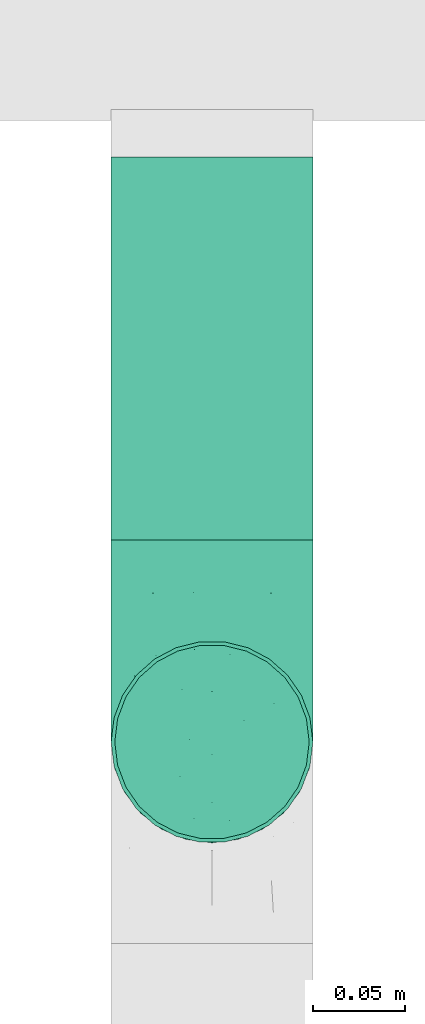
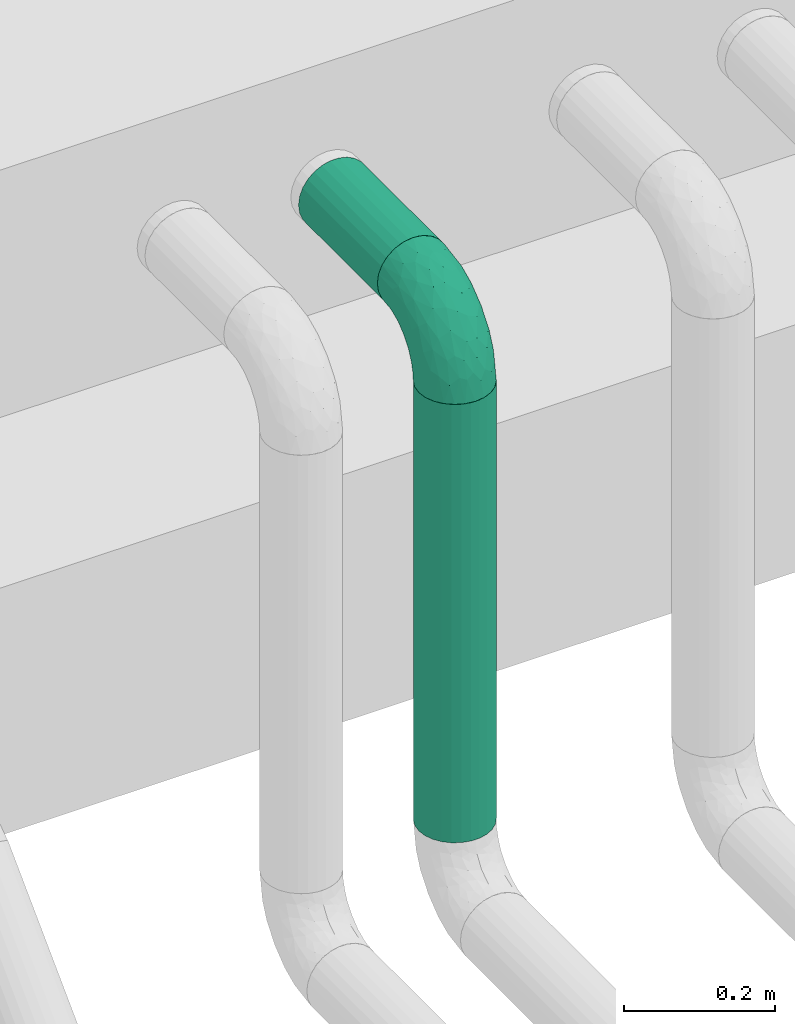
# One storey, part 8 of 91: 2 flow segments, 1 flow fitting.
"""IFC2X3 building model written with IfcOpenShell, lengths in millimetres."""

from ifc_helpers import new_model, entity, si_unit, converted_unit, derived_unit, direction, frame, origin_with_axes, origin_2d_with_axis, place, context, subcontext, project, spatial, hollow_circle, extrude, open_shell, surface_model, source, transform, mapped, material, layer, layer_set, layer_usage, type_object, element, save


model = new_model("IFC2X3")

# Units and contexts
model_context = context("Model", 3, precision=1e-05, world=origin_with_axes(), true_north=direction((0.0, 1.0)))
body_context = subcontext(model_context, "Body", "Model", "MODEL_VIEW")
ifc_project = project(units=[si_unit("AREAUNIT", "SQUARE_METRE"), si_unit("VOLUMEUNIT", "CUBIC_METRE", prefix="DECI"), si_unit("TIMEUNIT", "SECOND"), si_unit("THERMODYNAMICTEMPERATUREUNIT", "DEGREE_CELSIUS"), si_unit("PRESSUREUNIT", "PASCAL"), si_unit("MASSUNIT", "GRAM", prefix="KILO"), si_unit("LENGTHUNIT", "METRE", prefix="MILLI"), si_unit("POWERUNIT", "WATT"), si_unit("ELECTRICCURRENTUNIT", "AMPERE"), si_unit("ELECTRICVOLTAGEUNIT", "VOLT"), derived_unit("VOLUMETRICFLOWRATEUNIT", [(si_unit("VOLUMEUNIT", "CUBIC_METRE", prefix="DECI"), 1), (si_unit("TIMEUNIT", "SECOND"), -1)]), derived_unit("LINEARVELOCITYUNIT", [(si_unit("LENGTHUNIT", "METRE"), 1), (si_unit("TIMEUNIT", "SECOND"), -1)]), derived_unit("MASSDENSITYUNIT", [(si_unit("MASSUNIT", "GRAM", prefix="KILO"), 1), (si_unit("VOLUMEUNIT", "CUBIC_METRE"), -1)]), converted_unit("PLANEANGLEUNIT", "DEGREE", entity("IfcRatioMeasure", 0.01745), si_unit("PLANEANGLEUNIT", "RADIAN"), dimensions=[0, 0, 0, 0, 0, 0, 0])], contexts=[model_context])

# Site, building, storey
site_placement = place(None, origin_with_axes())
site = spatial("IfcSite", under=ifc_project, at=site_placement, CompositionType="ELEMENT")
building_placement = place(site_placement, origin_with_axes())
building = spatial("IfcBuilding", under=site, at=building_placement, Name="mc-building", CompositionType="ELEMENT")
storey_placement = place(building_placement, frame((0.0, 0.0, 8700.0), z_axis=(0.0, 0.0, 1.0), x_axis=(1.0, 0.0, 0.0)))
storey = spatial("IfcBuildingStorey", under=building, at=storey_placement, CompositionType="ELEMENT", Elevation=8700.0)

# Flow segments
ifc_material = material(Name="FZ1")
ifc_layer = layer(ifc_material, 0.0)
ifc_layer_set = layer_set([ifc_layer], Name="FZ1")
ifc_layer_usage = layer_usage(ifc_layer_set, "AXIS1", "POSITIVE", 0.0)
duct_segment_type = type_object("IfcDuctSegmentType", PredefinedType="RIGIDSEGMENT")
shared_shape_1 = source(origin_with_axes(), body_context, "Body", "SweptSolid", [
    extrude(hollow_circle(Radius=55.0, WallThickness=2.0, at=origin_2d_with_axis()), frame((0.0, 0.0, 0.0), z_axis=(1.0, 0.0, 0.0), x_axis=(0.0, 1.0, 0.0)), (0.0, 0.0, 1.0), 709.0),
])
flow_segment_1_placement = place(storey_placement, frame((8592.78509, 2612.35324, 1234.0), z_axis=(0.0, 1.0, 0.0), x_axis=(0.0, 0.0, -1.0)))
element("IfcFlowSegment", 1, at=flow_segment_1_placement, inside=storey, type_object=duct_segment_type, material=ifc_layer_usage, context=body_context, shape_type="MappedRepresentation", body=[
    mapped(shared_shape_1, transform((0.0, 0.0, 0.0), scale=1.0)),
])
shared_shape_2 = source(origin_with_axes(), body_context, "Body", "SweptSolid", [
    extrude(hollow_circle(Radius=55.0, WallThickness=2.0, at=origin_2d_with_axis()), frame((0.0, 0.0, 0.0), z_axis=(1.0, 0.0, 0.0), x_axis=(0.0, 1.0, 0.0)), (0.0, 0.0, 1.0), 208.9),
])
flow_segment_2_placement = place(storey_placement, frame((8592.78509, 2931.20513, 1344.0), z_axis=(0.0, 0.0, 1.0), x_axis=(0.0, -1.0, 0.0)))
element("IfcFlowSegment", 2, at=flow_segment_2_placement, inside=storey, type_object=duct_segment_type, material=ifc_layer_usage, context=body_context, shape_type="MappedRepresentation", body=[
    mapped(shared_shape_2, transform((0.0, 0.0, 0.0), scale=1.0, scale2=1.0, scale3=1.0, uniform=False)),
])

# Flow fitting
duct_fitting_type = type_object("IfcDuctFittingType", Name="BU", PredefinedType="BEND")
shared_shape_3 = source(origin_with_axes(), body_context, "Body", "SurfaceModel", [
    surface_model("IfcShellBasedSurfaceModel", [(-110.0, 0.0, -55.0), (-110.0, -14.23505, -53.12592), (-110.0, 14.23505, -53.12592), (-110.0, 53.12592, 14.23505), (-110.0, 27.5, -47.63139), (-110.0, 38.89087, -38.89087), (-110.0, -55.0, 0.0), (-110.0, -53.12592, 14.23505), (-110.0, -38.89087, -38.89087), (-110.0, -27.5, -47.63139), (-110.0, -53.12592, -14.23505), (-110.0, -47.63139, -27.5), (-110.0, -14.23505, 53.12592), (-110.0, 14.23505, 53.12592), (-110.0, 27.5, 47.63139), (-110.0, -47.63139, 27.5), (-110.0, -38.89087, 38.89087), (-110.0, -27.5, 47.63139), (-110.0, 0.0, 55.0), (-110.0, 55.0, 0.0), (-110.0, 53.12592, -14.23505), (-110.0, 47.63139, -27.5), (-110.0, 47.63139, 27.5), (-110.0, 38.89087, 38.89087), (-14.23505, 110.0, -53.12592), (-55.0, 110.0, 0.0), (0.0, 110.0, -55.0), (-27.5, 110.0, -47.63139), (-38.89087, 110.0, -38.89087), (-47.63139, 110.0, -27.5), (38.89087, 110.0, -38.89087), (53.12592, 110.0, 14.23505), (27.5, 110.0, -47.63139), (14.23505, 110.0, -53.12592), (47.63139, 110.0, -27.5), (53.12592, 110.0, -14.23505), (55.0, 110.0, 0.0), (-53.12592, 110.0, -14.23505), (-53.12592, 110.0, 14.23505), (-47.63139, 110.0, 27.5), (-38.89087, 110.0, 38.89087), (-27.5, 110.0, 47.63139), (0.0, 110.0, 55.0), (-14.23505, 110.0, 53.12592), (38.89087, 110.0, 38.89087), (47.63139, 110.0, 27.5), (27.5, 110.0, 47.63139), (14.23505, 110.0, 53.12592), (-64.21732, 48.68956, 43.63444), (-76.6405, 38.18013, 45.55988), (-60.44912, 32.56953, 51.94617), (-76.00813, 5.38378, 55.0), (-90.15553, 11.94394, 54.09138), (-78.5998, 26.77405, 50.81338), (-70.18771, 18.55163, 54.03432), (-75.55424, 54.2118, 32.41257), (-93.27622, 45.77614, 33.48188), (-96.12334, 22.13664, 50.81337), (-21.00813, 45.34362, 55.0), (-18.36258, 70.48427, 54.04484), (-32.04182, 59.64019, 52.24446), (-63.88653, 74.77858, 17.99134), (-74.66383, 63.08407, 19.92123), (-63.60674, 66.07878, 29.97482), (-99.597, 52.72185, 18.52927), (-93.11138, 56.59448, 10.50359), (-98.21577, 57.34403, 0.0), (-53.42855, 92.60092, 21.04759), (-88.54852, 54.8376, 21.04759), (-11.86161, 90.23965, 54.10313), (-5.38378, 76.00813, 55.0), (-57.34403, 98.21577, 0.0), (-56.64619, 93.12774, 10.22088), (-45.34362, 21.00813, 55.0), (-44.60838, 44.60838, 52.13415), (-92.68484, 35.46673, 43.63443), (-22.25266, 95.40765, 50.81337), (-35.97783, 90.61597, 43.63443), (-43.70931, 69.58671, 44.47149), (-27.23711, 77.39884, 50.81337), (-57.2828, 79.3123, 24.9774), (-58.67786, 84.31125, 16.04456), (-82.93277, 60.36161, 12.91784), (-49.88337, 54.51816, 47.224), (-74.57753, 66.83759, 9.55742), (-45.35812, 94.97281, 33.48188), (-59.18663, 88.95241, 0.0), (-51.517, 78.6292, 33.48188), (-65.14788, 80.03077, 0.0), (-56.45322, 62.06476, 39.63545), (-88.95241, 59.18663, 0.0), (-71.10913, 71.10913, 0.0), (-80.03077, 65.14788, 0.0), (-94.9309, 45.36788, -33.48188), (-93.11358, 56.60141, -10.46614), (-99.64997, 52.79499, -18.30015), (-90.20425, 36.08686, -43.63443), (-79.99933, 46.56772, -37.92748), (-76.00813, 5.38378, -55.0), (-72.75364, 19.68651, -53.60527), (-45.34362, 21.00813, -55.0), (-21.91957, 65.12078, -53.85897), (-5.38378, 76.00813, -55.0), (-21.00813, 45.34362, -55.0), (-35.41876, 92.89265, -43.63443), (-91.10309, 11.02766, -54.21832), (-45.77614, 93.27622, -33.48188), (-90.50474, 23.21022, -50.81337), (-70.92854, 33.31794, -49.51754), (-78.52933, 63.35627, -11.73997), (-24.91508, 84.05606, -50.81337), (-88.78941, 54.74452, -21.04759), (-69.59921, 57.34866, -33.48187), (-73.36422, 62.46673, -22.94182), (-63.49062, 67.59111, -28.46929), (-56.59448, 93.11138, -10.50359), (-54.8376, 88.54852, -21.04759), (-54.10679, 75.85581, -32.31867), (-57.75956, 31.09612, -52.80882), (-52.72185, 99.597, -18.52927), (-12.62913, 89.46304, -53.99097), (-34.46825, 66.46123, -50.04329), (-43.9837, 43.9837, -52.42279), (-65.78527, 72.58348, -17.68796), (-70.34468, 43.65295, -44.21951), (-57.47001, 51.99467, -44.91465), (-60.72547, 82.29174, -12.88567), (-42.34915, 74.24548, -43.63444), (-57.25194, 63.5016, -38.08211), (-80.95344, 53.56991, -29.32027), (-52.32891, 4.55257, -54.0482), (32.52942, 47.13398, -30.48571), (14.88266, 20.92917, -33.7947), (14.95561, 36.05775, -42.26543), (30.24048, 70.09027, -41.7461), (19.3559, 65.35825, -48.00507), (-70.35075, -46.44478, -19.5952), (-47.13398, -32.52942, -30.48571), (-28.49299, -30.5778, -16.4009), (-4.55257, 52.32891, -54.0482), (-22.4954, 22.4954, -53.25347), (-75.47368, -11.22546, -52.60718), (-81.32209, -51.5606, -9.98467), (-80.81763, -41.84862, -32.14655), (-70.09027, -30.24048, -41.7461), (-36.05774, -14.95561, -42.26543), (-9.15831, -10.852, -27.8997), (-65.35825, -19.3559, -48.00507), (11.22546, 75.47368, -52.60718), (3.94376, 43.9333, -50.53315), (-13.39742, 13.39743, -48.13058), (-43.9333, -3.94376, -50.53315), (49.37776, 67.29486, 0.0), (41.8609, 47.82256, -9.92641), (50.20582, 74.51695, -9.9731), (18.93131, 11.7156, -17.56239), (-27.5, -32.89419, 0.0), (-1.23348, -12.25375, -12.18106), (41.84862, 80.81763, -32.14655), (35.70604, 41.31408, -20.38235), (46.44478, 70.35075, -19.5952), (32.89419, 27.5, 0.0), (6.67262, -6.67262, 0.0), (-67.29486, -49.37776, 0.0), (-50.36265, -42.95545, -9.51562), (-5.47251, 5.47251, -39.92906), (-70.35075, -46.44478, 19.5952), (-74.51695, -50.20582, 9.9731), (-41.31407, -35.70604, 20.38235), (-47.13398, -32.52942, 30.48571), (-80.81763, -41.84862, 32.14655), (-4.55257, 52.32891, 54.0482), (11.22546, 75.47368, 52.60718), (-43.9333, -3.94376, 50.53315), (-65.35825, -19.3559, 48.00507), (-36.05774, -14.95561, 42.26543), (-70.09027, -30.24048, 41.7461), (-11.7156, -18.93131, 17.56239), (30.5778, 28.49299, 16.4009), (12.25375, 1.23348, 12.18106), (51.5606, 81.32209, 9.98467), (42.95545, 50.36265, 9.51562), (-75.47368, -11.22546, 52.60718), (-52.32891, 4.55257, 54.0482), (3.94376, 43.9333, 50.53315), (-22.4954, 22.4954, 53.25347), (-13.39742, 13.39743, 48.13058), (10.852, 9.15831, 27.8997), (-20.92916, -14.88266, 33.79469), (-47.82256, -41.8609, 9.92641), (32.52942, 47.13398, 30.48571), (46.44478, 70.35075, 19.5952), (41.84862, 80.81763, 32.14655), (30.24048, 70.09027, 41.7461), (19.3559, 65.35825, 48.00507), (14.95561, 36.05775, 42.26543), (-5.47251, 5.47251, 39.92906)], [open_shell([[[0, 1, 2]], [[2, 3, 4]], [[4, 3, 5]], [[2, 6, 7]], [[8, 6, 9]], [[1, 9, 6]], [[10, 6, 11]], [[8, 11, 6]], [[6, 2, 1]], [[12, 13, 14]], [[15, 2, 7]], [[16, 17, 2]], [[2, 17, 12]], [[12, 18, 13]], [[19, 20, 3]], [[5, 3, 21]], [[20, 21, 3]], [[22, 3, 2]], [[23, 22, 2]], [[12, 14, 2]], [[2, 14, 23]], [[15, 16, 2]], [[24, 25, 26]], [[27, 25, 24]], [[25, 28, 29]], [[28, 25, 27]], [[30, 26, 31]], [[26, 30, 32]], [[32, 33, 26]], [[34, 31, 35]], [[31, 34, 30]], [[35, 31, 36]], [[29, 37, 25]], [[38, 39, 26]], [[39, 40, 26]], [[41, 42, 40]], [[42, 26, 40]], [[42, 41, 43]], [[26, 44, 45]], [[31, 26, 45]], [[26, 46, 44]], [[47, 46, 26]], [[42, 47, 26]], [[25, 38, 26]], [[48, 49, 50]], [[18, 51, 52]], [[53, 54, 50]], [[55, 56, 49]], [[56, 22, 23]], [[13, 57, 14]], [[58, 59, 60]], [[61, 62, 63]], [[3, 64, 65]], [[53, 52, 54]], [[3, 65, 66]], [[67, 39, 38]], [[56, 68, 64]], [[65, 64, 68]], [[69, 59, 70]], [[38, 71, 72]], [[73, 58, 74]], [[75, 49, 56]], [[76, 69, 43]], [[53, 57, 52]], [[77, 78, 79]], [[41, 76, 43]], [[43, 69, 42]], [[55, 68, 56]], [[23, 14, 75]], [[76, 77, 79]], [[80, 67, 81]], [[62, 82, 68]], [[60, 78, 83]], [[62, 84, 82]], [[85, 77, 40]], [[81, 67, 72]], [[86, 72, 71]], [[87, 85, 67]], [[61, 81, 88]], [[77, 41, 40]], [[78, 77, 87]], [[23, 75, 56]], [[83, 89, 48]], [[85, 40, 39]], [[62, 68, 55]], [[89, 87, 63]], [[83, 48, 50]], [[57, 75, 14]], [[49, 75, 53]], [[67, 85, 39]], [[87, 77, 85]], [[63, 62, 55]], [[89, 55, 48]], [[80, 63, 87]], [[66, 65, 90]], [[66, 19, 3]], [[84, 91, 92]], [[92, 90, 82]], [[65, 82, 90]], [[61, 84, 62]], [[92, 82, 84]], [[68, 82, 65]], [[3, 22, 64]], [[56, 64, 22]], [[38, 25, 71]], [[81, 72, 86]], [[38, 72, 67]], [[91, 61, 88]], [[80, 81, 61]], [[63, 80, 61]], [[67, 80, 87]], [[77, 76, 41]], [[79, 59, 69]], [[79, 69, 76]], [[42, 69, 70]], [[60, 59, 79]], [[58, 70, 59]], [[78, 60, 79]], [[58, 60, 74]], [[52, 57, 13]], [[75, 57, 53]], [[18, 52, 13]], [[52, 51, 54]], [[51, 73, 54]], [[50, 73, 74]], [[73, 50, 54]], [[50, 74, 83]], [[60, 83, 74]], [[89, 83, 78]], [[87, 89, 78]], [[55, 89, 63]], [[50, 49, 53]], [[55, 49, 48]], [[81, 86, 88]], [[91, 84, 61]], [[5, 21, 93]], [[90, 94, 66]], [[20, 94, 95]], [[96, 93, 97]], [[98, 99, 100]], [[96, 4, 5]], [[101, 102, 103]], [[28, 27, 104]], [[2, 105, 0]], [[104, 106, 28]], [[99, 105, 107]], [[108, 107, 96]], [[90, 109, 94]], [[107, 2, 4]], [[20, 66, 94]], [[27, 24, 110]], [[109, 111, 94]], [[112, 113, 114]], [[37, 115, 71]], [[116, 106, 117]], [[99, 118, 100]], [[116, 115, 119]], [[37, 119, 115]], [[24, 120, 110]], [[121, 110, 101]], [[119, 106, 116]], [[101, 110, 120]], [[122, 103, 100]], [[117, 123, 116]], [[124, 125, 108]], [[115, 116, 126]], [[106, 29, 28]], [[26, 102, 120]], [[127, 104, 110]], [[97, 124, 96]], [[125, 122, 118]], [[128, 127, 125]], [[96, 5, 93]], [[115, 126, 86]], [[117, 106, 127]], [[111, 113, 129]], [[95, 93, 21]], [[97, 129, 112]], [[110, 104, 27]], [[106, 104, 127]], [[96, 107, 4]], [[99, 107, 108]], [[99, 108, 118]], [[105, 99, 98]], [[112, 114, 128]], [[121, 125, 127]], [[20, 19, 66]], [[109, 90, 92]], [[94, 111, 95]], [[91, 123, 109]], [[129, 113, 112]], [[93, 95, 111]], [[21, 20, 95]], [[71, 115, 86]], [[71, 25, 37]], [[123, 91, 88]], [[126, 116, 123]], [[123, 88, 126]], [[86, 126, 88]], [[37, 29, 119]], [[106, 119, 29]], [[129, 93, 111]], [[124, 112, 125]], [[0, 105, 98]], [[107, 105, 2]], [[125, 118, 108]], [[100, 118, 122]], [[93, 129, 97]], [[113, 111, 109]], [[109, 123, 113]], [[114, 123, 117]], [[123, 114, 113]], [[128, 114, 117]], [[127, 128, 117]], [[112, 128, 125]], [[103, 122, 101]], [[110, 121, 127]], [[101, 122, 121]], [[125, 121, 122]], [[26, 120, 24]], [[101, 120, 102]], [[96, 124, 108]], [[92, 91, 109]], [[112, 124, 97]], [[100, 130, 98]], [[131, 132, 133]], [[32, 134, 135]], [[136, 137, 138]], [[139, 140, 103]], [[98, 141, 0]], [[142, 10, 136]], [[143, 144, 137]], [[6, 10, 142]], [[137, 145, 146]], [[144, 147, 145]], [[143, 136, 11]], [[11, 136, 10]], [[8, 143, 11]], [[148, 149, 139]], [[8, 9, 144]], [[9, 1, 147]], [[130, 141, 98]], [[103, 140, 100]], [[148, 135, 149]], [[150, 151, 140]], [[152, 153, 154]], [[130, 140, 151]], [[148, 26, 33]], [[147, 1, 141]], [[155, 146, 132]], [[156, 138, 157]], [[134, 30, 158]], [[150, 140, 149]], [[158, 30, 34]], [[30, 134, 32]], [[153, 159, 160]], [[131, 160, 159]], [[144, 145, 137]], [[36, 152, 154]], [[146, 138, 137]], [[155, 161, 162]], [[158, 160, 131]], [[133, 149, 135]], [[156, 163, 164]], [[163, 142, 164]], [[139, 103, 102]], [[153, 152, 161]], [[34, 35, 160]], [[162, 157, 155]], [[132, 165, 133]], [[157, 146, 155]], [[140, 130, 100]], [[141, 130, 151]], [[141, 151, 147]], [[141, 1, 0]], [[102, 26, 148]], [[140, 139, 149]], [[102, 148, 139]], [[135, 33, 32]], [[151, 150, 145]], [[9, 147, 144]], [[151, 145, 147]], [[145, 165, 146]], [[135, 148, 33]], [[133, 135, 134]], [[131, 133, 134]], [[133, 165, 150]], [[133, 150, 149]], [[145, 150, 165]], [[132, 131, 159]], [[146, 165, 132]], [[160, 158, 34]], [[134, 158, 131]], [[144, 143, 8]], [[136, 143, 137]], [[155, 153, 161]], [[154, 153, 160]], [[153, 155, 159]], [[132, 159, 155]], [[160, 35, 154]], [[36, 154, 35]], [[164, 136, 138]], [[6, 142, 163]], [[136, 164, 142]], [[156, 164, 138]], [[156, 157, 162]], [[146, 157, 138]], [[15, 7, 166]], [[6, 163, 167]], [[168, 169, 166]], [[166, 169, 170]], [[171, 172, 70]], [[173, 174, 175]], [[17, 176, 174]], [[177, 156, 162]], [[176, 16, 170]], [[170, 16, 15]], [[161, 178, 179]], [[152, 180, 181]], [[182, 173, 183]], [[18, 12, 182]], [[184, 185, 186]], [[183, 185, 73]], [[183, 73, 51]], [[177, 187, 188]], [[189, 168, 166]], [[187, 178, 190]], [[16, 176, 17]], [[161, 152, 181]], [[45, 191, 31]], [[45, 44, 192]], [[192, 191, 45]], [[180, 36, 31]], [[193, 194, 195]], [[46, 47, 194]], [[193, 195, 190]], [[193, 44, 46]], [[172, 42, 70]], [[185, 58, 73]], [[189, 163, 156]], [[163, 189, 167]], [[70, 58, 171]], [[184, 171, 185]], [[169, 188, 175]], [[180, 31, 191]], [[192, 193, 190]], [[191, 190, 178]], [[182, 174, 173]], [[194, 47, 172]], [[190, 195, 187]], [[186, 185, 173]], [[162, 179, 177]], [[188, 196, 175]], [[179, 187, 177]], [[185, 171, 58]], [[172, 171, 184]], [[172, 184, 194]], [[172, 47, 42]], [[51, 18, 182]], [[185, 183, 173]], [[51, 182, 183]], [[174, 12, 17]], [[184, 186, 195]], [[46, 194, 193]], [[184, 195, 194]], [[195, 196, 187]], [[174, 182, 12]], [[175, 174, 176]], [[169, 175, 176]], [[175, 196, 186]], [[175, 186, 173]], [[195, 186, 196]], [[188, 169, 168]], [[187, 196, 188]], [[166, 170, 15]], [[176, 170, 169]], [[193, 192, 44]], [[191, 192, 190]], [[177, 189, 156]], [[167, 189, 166]], [[189, 177, 168]], [[188, 168, 177]], [[166, 7, 167]], [[6, 167, 7]], [[181, 191, 178]], [[36, 180, 152]], [[191, 181, 180]], [[161, 181, 178]], [[161, 179, 162]], [[187, 179, 178]]])]),
])
flow_fitting_placement = place(storey_placement, frame((8592.78509, 2612.35324, 1344.0), z_axis=(-1.0, 0.0, 0.0), x_axis=(0.0, 0.0, 1.0)))
element("IfcFlowFitting", 3, at=flow_fitting_placement, inside=storey, type_object=duct_fitting_type, Name="BU", context=body_context, shape_type="MappedRepresentation", body=[
    mapped(shared_shape_3, transform((0.0, 0.0, 0.0), scale=1.0)),
])

save(model, "model.ifc")
